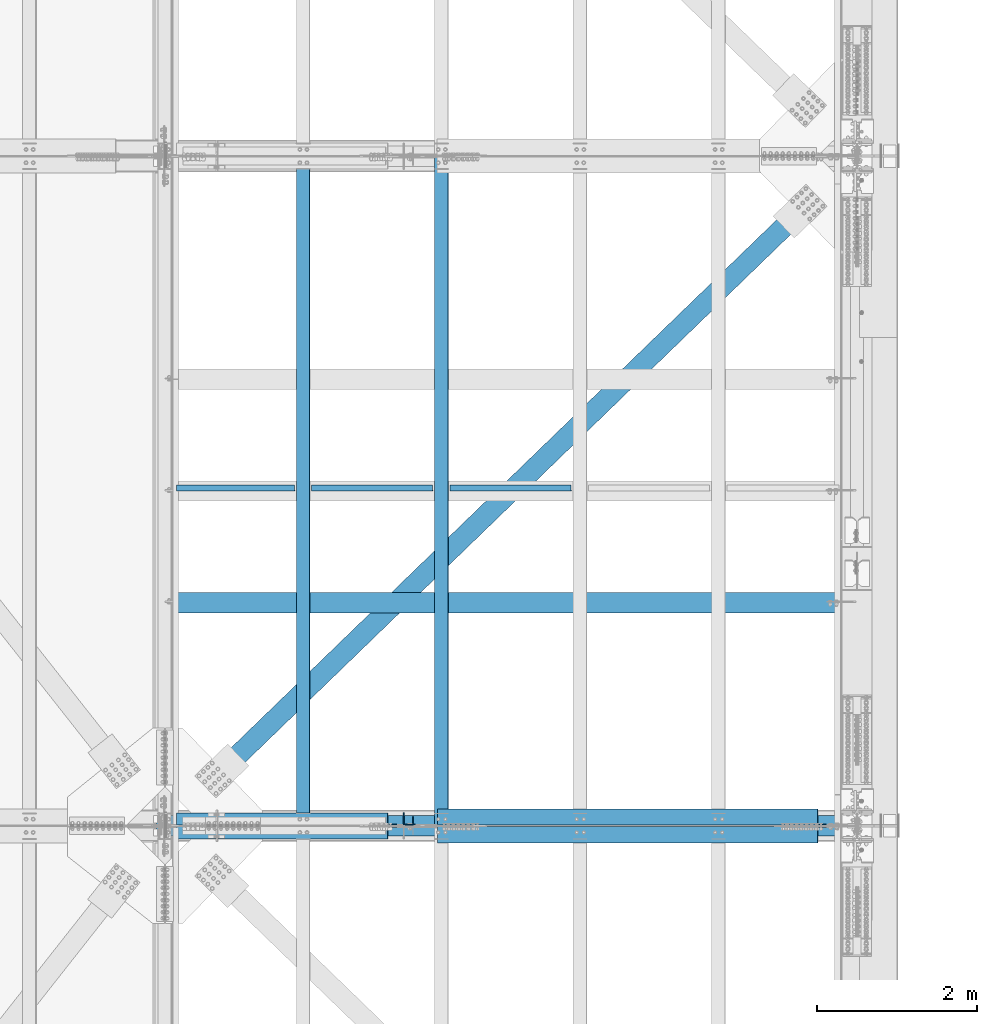
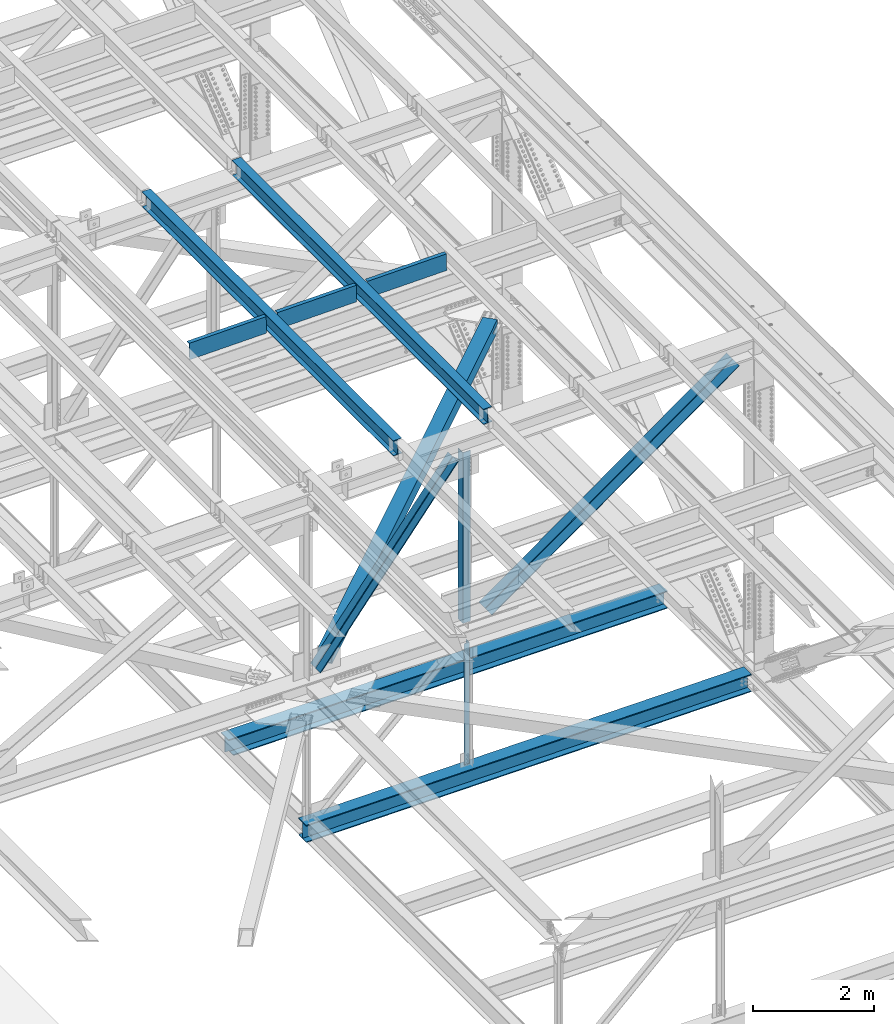
# One storey, part 1972 of 3843: 10 beams, 4 members, 14 elements without a shape of their own.
"""IFC2X3 building model written with IfcOpenShell, lengths in millimetres."""

from ifc_helpers import new_model, si_unit, frame, origin_with_axes, place, context, subcontext, project, spatial, faceted_brep, material, type_object, element, aggregate, save


model = new_model("IFC2X3")

# Units and contexts
model_context = context("Model", 3, precision=1e-05, world=origin_with_axes())
body_context = subcontext(model_context, "Body", "Model", "MODEL_VIEW")
ifc_project = project(units=[si_unit("LENGTHUNIT", "METRE", prefix="MILLI"), si_unit("AREAUNIT", "SQUARE_METRE"), si_unit("VOLUMEUNIT", "CUBIC_METRE"), si_unit("MASSUNIT", "GRAM", prefix="KILO"), si_unit("TIMEUNIT", "SECOND"), si_unit("PLANEANGLEUNIT", "RADIAN"), si_unit("SOLIDANGLEUNIT", "STERADIAN"), si_unit("THERMODYNAMICTEMPERATUREUNIT", "DEGREE_CELSIUS"), si_unit("LUMINOUSINTENSITYUNIT", "LUMEN")], contexts=[model_context])

# Site, building, storey
site_placement = place(None, origin_with_axes())
site = spatial("IfcSite", under=ifc_project, at=site_placement, CompositionType="ELEMENT")
building_placement = place(site_placement, origin_with_axes())
building = spatial("IfcBuilding", under=site, at=building_placement, Name="Undefined", CompositionType="ELEMENT")
storey_placement = place(building_placement, origin_with_axes())
storey = spatial("IfcBuildingStorey", under=building, at=storey_placement, Name="Undefined", CompositionType="ELEMENT", Elevation=0.0)

# Assembly, beam
assembly_1_placement = place(storey_placement, origin_with_axes())
assembly_1 = element("IfcElementAssembly", 1, at=assembly_1_placement, inside=storey, Name="ANGLE", AssemblyPlace="NOTDEFINED", PredefinedType="RIGID_FRAME")
ifc_material_1 = material(Name="STEEL/A572-50")
beam_type_1 = type_object("IfcBeamType", Name="L4X4X3/8", PredefinedType="NOTDEFINED")
beam_1_placement = place(assembly_1_placement, frame((80060.8, 58975.625, 42337.1940566244), z_axis=(-1.0, 0.0, 0.0), x_axis=(0.0, 0.0, -1.0)))
beam_1 = element("IfcBeam", 2, at=beam_1_placement, type_object=beam_type_1, material=ifc_material_1, Name="ANGLE", ObjectType="L4X4X3/8", context=body_context, shape_type="Brep", body=[
    faceted_brep([(208.997248726504, 50.8000000000029, -50.8000000000029), (208.997248726504, 50.8000000000029, 50.8000000000029), (2659.86733991184, 50.8000000000029, 50.8000000000029), (2659.86733991184, 50.8000000000029, -50.8000000000029), (208.997248726504, 41.2750000000015, 50.8000000000029), (2659.86733991184, 41.2750000000015, 50.8000000000029), (208.997248726504, 41.2750000000015, -41.2749999999942), (2659.86733991184, 41.2750000000015, -41.2749999999942), (208.997248726504, -50.8000000000029, -41.2749999999942), (2659.86733991184, -50.8000000000029, -41.2749999999942), (208.997248726504, -50.8000000000029, -50.8000000000029), (2659.86733991184, -50.8000000000029, -50.8000000000029)], [[[0, 1, 2, 3]], [[1, 4, 5, 2]], [[4, 6, 7, 5]], [[6, 8, 9, 7]], [[8, 10, 11, 9]], [[10, 0, 3, 11]], [[5, 7, 9, 11, 3, 2]], [[10, 8, 6, 4, 1, 0]]]),
])
aggregate(assembly_1, [beam_1])

assembly_2_placement = place(storey_placement, origin_with_axes())
assembly_2 = element("IfcElementAssembly", 3, at=assembly_2_placement, inside=storey, Name="BEAM", AssemblyPlace="NOTDEFINED", PredefinedType="RIGID_FRAME")
ifc_material_2 = material(Name="STEEL/A992")
beam_type_2 = type_object("IfcBeamType", Name="W12X26", PredefinedType="NOTDEFINED")
beam_2_placement = place(assembly_2_placement, frame((80463.909262389, 58915.3983935772, 46592.2546931434), z_axis=(-0.0211520982257644, 0.00063245100018685, 0.999776069300711), x_axis=(2.19999991776632e-08, 0.999999799913661, -0.000632591999945398)))
beam_2 = element("IfcBeam", 4, at=beam_2_placement, type_object=beam_type_2, material=ifc_material_2, Name="BEAM", ObjectType="W12X26", context=body_context, shape_type="Brep", body=[
    faceted_brep([(12.7011052740709, 82.550000000163, -155.575000000317), (12.6950811777642, 82.5500000001775, -146.050000000301), (8343.89674809582, 82.5499999787862, -146.049999973642), (8343.90277219211, 82.5499999787717, -155.574999973665), (12.6940208345186, 3.17499999974098, -146.050000000301), (8343.89568775256, 3.17499997834966, -146.049999973642), (12.5092818811318, 3.17500000026484, 146.050000000389), (8343.71094879918, 3.17499997887353, 146.05000002704), (12.5103422243774, 82.5500000007014, 146.050000000389), (8343.71200914242, 82.5499999793101, 146.05000002704), (12.5043181280635, 82.550000000716, 155.575000000419), (8343.70598504612, 82.5499999793246, 155.575000027071), (12.5021126141219, -82.5500000002066, 155.575000000419), (8343.70377953217, -82.5500000215834, 155.575000027071), (12.5081367104212, -82.5500000002357, 146.050000000389), (8343.70980362848, -82.5500000216271, 146.05000002704), (12.5091970536669, -3.17499999978463, 146.050000000389), (8343.71086397171, -3.1750000211614, 146.05000002704), (12.6939360070683, -3.1750000003085, -146.050000000301), (8343.89560292511, -3.17500002169982, -146.049999973642), (12.6928756638226, -82.5500000007596, -146.050000000301), (8343.89454258186, -82.5500000221509, -146.049999973642), (12.698899760122, -82.5500000007742, -155.575000000317), (8343.90056667817, -82.5500000221655, -155.574999973665)], [[[0, 1, 2, 3]], [[1, 4, 5, 2]], [[4, 6, 7, 5]], [[6, 8, 9, 7]], [[8, 10, 11, 9]], [[10, 12, 13, 11]], [[12, 14, 15, 13]], [[14, 16, 17, 15]], [[16, 18, 19, 17]], [[18, 20, 21, 19]], [[20, 22, 23, 21]], [[22, 0, 3, 23]], [[5, 7, 9, 11, 13, 15, 17, 19, 21, 23, 3, 2]], [[22, 20, 18, 16, 14, 12, 10, 8, 6, 4, 1, 0]]]),
])
aggregate(assembly_2, [beam_2])

assembly_3_placement = place(storey_placement, origin_with_axes())
assembly_3 = element("IfcElementAssembly", 5, at=assembly_3_placement, inside=storey, Name="BEAM", AssemblyPlace="NOTDEFINED", PredefinedType="RIGID_FRAME")
beam_3_placement = place(assembly_3_placement, frame((78736.7092624125, 58915.3943655038, 46558.3500046998), z_axis=(-0.0211520978869958, 0.000606560000211177, 0.999776085351088), x_axis=(2.19999995306454e-08, 0.999999815960571, -0.00060669499997619)))
beam_3 = element("IfcBeam", 6, at=beam_3_placement, type_object=beam_type_2, material=ifc_material_2, Name="BEAM", ObjectType="W12X26", context=body_context, shape_type="Brep", body=[
    faceted_brep([(12.7011052740709, 82.550000000163, -155.575000000317), (12.6952824190448, 82.5500000002939, -146.050000000556), (8343.89681571124, 82.5499999796593, -146.050000008661), (8343.90259319375, 82.5499999796593, -155.575000008685), (12.6942655559615, 3.17499999984284, -146.050000000381), (8343.89579884816, 3.17499997922278, -146.050000008487), (12.5170894254115, 3.17500000010477, 146.050000000352), (8343.7186227176, 3.17499997948471, 146.049999992247), (12.5181062884949, 82.5500000005559, 146.050000000178), (8343.7196395807, 82.5499999799358, 146.049999992065), (12.5123288059767, 82.5500000005559, 155.575000000194), (8343.71386209816, 82.5499999799358, 155.574999992095), (12.5102137307549, -82.5500000003813, 155.575000000557), (8343.71174702294, -82.5500000210013, 155.574999992459), (12.5159912132804, -82.5500000003667, 146.050000000541), (8343.71752450548, -82.5500000210013, 146.049999992429), (12.5170080763637, -3.17499999993015, 146.050000000367), (8343.71854136855, -3.17500002056477, 146.049999992261), (12.6941842069136, -3.17500000017753, -146.050000000374), (8343.89571749911, -3.17500002081215, -146.050000008472), (12.6931673438303, -82.5500000006286, -146.050000000192), (8343.89468100455, -82.5499999998865, -146.050000014839), (12.698899760122, -82.5500000007742, -155.575000000317), (8343.90047811854, -82.5500000212778, -155.575000008314)], [[[0, 1, 2, 3]], [[1, 4, 5, 2]], [[4, 6, 7, 5]], [[6, 8, 9, 7]], [[8, 10, 11, 9]], [[10, 12, 13, 11]], [[12, 14, 15, 13]], [[14, 16, 17, 15]], [[16, 18, 19, 17]], [[18, 20, 21, 19]], [[20, 22, 23, 21]], [[22, 0, 3, 23]], [[5, 7, 9, 11, 13, 15, 17, 19, 21, 23, 3, 2]], [[22, 20, 18, 16, 14, 12, 10, 8, 6, 4, 1, 0]]]),
])
aggregate(assembly_3, [beam_3])

assembly_4_placement = place(storey_placement, origin_with_axes())
assembly_4 = element("IfcElementAssembly", 7, at=assembly_4_placement, inside=storey, Name="BENT_PLATE", AssemblyPlace="NOTDEFINED", PredefinedType="RIGID_FRAME")
ifc_material_3 = material(Name="STEEL/A36")
beam_type_3 = type_object("IfcBeamType", PredefinedType="NOTDEFINED")
beam_4_placement = place(assembly_4_placement, frame((77895.7274919524, 63098.3625000036, 46362.5752806988), z_axis=(-0.999843583960508, 0.0, -0.0176863679992966), x_axis=(-0.0176863679992983, 0.0, 0.999843583960508)))
beam_4 = element("IfcBeam", 8, at=beam_4_placement, type_object=beam_type_3, material=ifc_material_3, Name="BENT_PLATE", context=body_context, shape_type="Brep", body=[
    faceted_brep([(2.31375452131033e-09, -4.76249999999709, -736.599999997517), (-2.30647856369615e-09, -4.76249999999709, 736.599999997474), (-2.30647856369615e-09, 4.76249999999709, 736.599999997474), (2.31375452131033e-09, 4.76249999999709, -736.599999997517), (327.024999947338, 4.76250000002619, 736.600000004051), (327.024999981979, 4.76250000002619, -736.600000004313), (336.549999981966, -4.76249999996799, -736.600000004328), (336.549999947325, -4.76249999996799, 736.600000004051), (327.024999959613, 71.4375000200889, 736.600000005245), (327.024999969712, 71.4375000446889, -736.60000000312), (336.549999959585, 71.4375000200962, 736.600000005245), (336.549999969691, 71.4375000446962, -736.600000003134)], [[[0, 1, 2, 3]], [[3, 2, 4, 5]], [[1, 0, 6, 7]], [[5, 4, 8, 9]], [[4, 2, 1, 7, 10, 8]], [[7, 6, 11, 10]], [[6, 0, 3, 5, 9, 11]], [[10, 11, 9, 8]]]),
])
aggregate(assembly_4, [beam_4])

assembly_5_placement = place(storey_placement, origin_with_axes())
assembly_5 = element("IfcElementAssembly", 9, at=assembly_5_placement, inside=storey, Name="BENT_PLATE", AssemblyPlace="NOTDEFINED", PredefinedType="RIGID_FRAME")
beam_5_placement = place(assembly_5_placement, frame((79602.4297787395, 63098.3625000037, 46392.7857615998), z_axis=(-0.999843583960508, 0.0, -0.0176863679992966), x_axis=(-0.0176863679992983, 0.0, 0.999843583960508)))
beam_5 = element("IfcBeam", 10, at=beam_5_placement, type_object=beam_type_3, material=ifc_material_3, Name="BENT_PLATE", context=body_context, shape_type="Brep", body=[
    faceted_brep([(2.38651409745216e-09, -4.76249999999709, -755.649999997448), (-2.37923813983798e-09, -4.76249999999709, 755.649999997433), (-2.37923813983798e-09, 4.76249999999709, 755.649999997433), (2.38651409745216e-09, 4.76249999999709, -755.649999997448), (327.024999945941, 4.76250000002619, 755.650000004171), (327.024999981295, 4.76250000002619, -755.650000004418), (336.549999981282, -4.76249999996799, -755.650000004447), (336.549999945928, -4.76249999996799, 755.650000004156), (327.024999958514, 71.4375000207219, 755.650000005364), (327.024999968708, 71.4375000458094, -755.650000003239), (336.549999958501, 71.4375000207219, 755.650000005349), (336.549999968687, 71.4375000458094, -755.650000003254)], [[[0, 1, 2, 3]], [[3, 2, 4, 5]], [[1, 0, 6, 7]], [[5, 4, 8, 9]], [[4, 2, 1, 7, 10, 8]], [[7, 6, 11, 10]], [[6, 0, 3, 5, 9, 11]], [[10, 11, 9, 8]]]),
])
aggregate(assembly_5, [beam_5])

assembly_6_placement = place(storey_placement, origin_with_axes())
assembly_6 = element("IfcElementAssembly", 11, at=assembly_6_placement, inside=storey, Name="BENT_PLATE", AssemblyPlace="NOTDEFINED", PredefinedType="RIGID_FRAME")
beam_6_placement = place(assembly_6_placement, frame((81329.6291454231, 63098.3625000037, 46423.3405616883), z_axis=(-0.999843583960508, 0.0, -0.0176863679992966), x_axis=(-0.0176863679992983, 0.0, 0.999843583960508)))
beam_6 = element("IfcBeam", 12, at=beam_6_placement, type_object=beam_type_3, material=ifc_material_3, Name="BENT_PLATE", context=body_context, shape_type="Brep", body=[
    faceted_brep([(2.38651409745216e-09, -4.76249999999709, -755.649999997448), (-2.37923813983798e-09, -4.76249999999709, 755.649999997433), (-2.37923813983798e-09, 4.76249999999709, 755.649999997433), (2.38651409745216e-09, 4.76249999999709, -755.649999997448), (327.024999945941, 4.76250000002619, 755.650000004171), (327.024999981295, 4.76250000002619, -755.650000004418), (336.549999981282, -4.76249999996799, -755.650000004447), (336.549999945928, -4.76249999996799, 755.650000004156), (327.024999958514, 71.4375000207219, 755.650000005364), (327.024999968708, 71.4375000458094, -755.650000003239), (336.549999958501, 71.4375000207219, 755.650000005349), (336.549999968687, 71.4375000458094, -755.650000003254)], [[[0, 1, 2, 3]], [[3, 2, 4, 5]], [[1, 0, 6, 7]], [[5, 4, 8, 9]], [[4, 2, 1, 7, 10, 8]], [[7, 6, 11, 10]], [[6, 0, 3, 5, 9, 11]], [[10, 11, 9, 8]]]),
])
aggregate(assembly_6, [beam_6])

# Assembly, member
assembly_7_placement = place(storey_placement, origin_with_axes())
assembly_7 = element("IfcElementAssembly", 13, at=assembly_7_placement, inside=storey, Name="ANGLE", AssemblyPlace="NOTDEFINED", PredefinedType="RIGID_FRAME")
member_type_1 = type_object("IfcMemberType", Name="L8X8X1/2", PredefinedType="NOTDEFINED")
member_1_placement = place(assembly_7_placement, frame((85648.8, 59026.425, 46335.9221366136), z_axis=(0.0, 1.0, 0.0), x_axis=(-0.813230724000052, 0.0, -0.581941397000035)))
member_1 = element("IfcMember", 14, at=member_1_placement, type_object=member_type_1, material=ifc_material_1, Name="ANGLE", ObjectType="L8X8X1/2", context=body_context, shape_type="Brep", body=[
    faceted_brep([(538.735498343696, 101.599999999675, -101.599999999999), (538.735498343696, 101.599999999675, 101.599999999999), (6369.12494995302, 101.599999993818, 101.599999999999), (6369.12494995302, 101.599999993818, -101.599999999999), (538.735498343711, 88.8999999996413, 101.599999999999), (6369.12494995302, 88.8999999937987, 101.599999999999), (538.735498343711, 88.8999999996413, -88.9000000000015), (6369.12494995302, 88.8999999937987, -88.9000000000015), (538.735498343711, -101.600000000752, -88.9000000000015), (6369.12494995302, -101.600000006609, -88.9000000000015), (538.735498343711, -101.600000000752, -101.599999999999), (6369.12494995302, -101.600000006609, -101.599999999999)], [[[0, 1, 2, 3]], [[1, 4, 5, 2]], [[4, 6, 7, 5]], [[6, 8, 9, 7]], [[8, 10, 11, 9]], [[10, 0, 3, 11]], [[5, 7, 9, 11, 3, 2]], [[10, 8, 6, 4, 1, 0]]]),
])
aggregate(assembly_7, [member_1])

assembly_8_placement = place(storey_placement, origin_with_axes())
assembly_8 = element("IfcElementAssembly", 15, at=assembly_8_placement, inside=storey, Name="ANGLE", AssemblyPlace="NOTDEFINED", PredefinedType="RIGID_FRAME")
member_2_placement = place(assembly_8_placement, frame((80060.7999993134, 58804.175, 42337.1940577753), z_axis=(0.0, -1.0, 0.0), x_axis=(0.813230724000049, 0.0, 0.581941397000038)))
member_2 = element("IfcMember", 16, at=member_2_placement, type_object=member_type_1, material=ifc_material_1, Name="ANGLE", ObjectType="L8X8X1/2", context=body_context, shape_type="Brep", body=[
    faceted_brep([(502.233740769108, 101.600000000715, -101.599999999999), (502.233740769108, 101.600000000715, 101.599999999999), (6332.62319237844, 101.600000006572, 101.599999999999), (6332.62319237844, 101.600000006572, -101.599999999999), (502.233740769123, 88.9000000006963, 101.599999999999), (6332.62319237844, 88.9000000065462, 101.599999999999), (502.233740769123, 88.9000000006963, -88.9000000000015), (6332.62319237844, 88.9000000065462, -88.9000000000015), (502.233740769108, -101.599999999711, -88.9000000000015), (6332.62319237845, -101.599999993861, -88.9000000000015), (502.233740769108, -101.599999999711, -101.599999999999), (6332.62319237845, -101.599999993861, -101.599999999999)], [[[0, 1, 2, 3]], [[1, 4, 5, 2]], [[4, 6, 7, 5]], [[6, 8, 9, 7]], [[8, 10, 11, 9]], [[10, 0, 3, 11]], [[5, 7, 9, 11, 3, 2]], [[10, 8, 6, 4, 1, 0]]]),
])
aggregate(assembly_8, [member_2])

assembly_9_placement = place(storey_placement, origin_with_axes())
assembly_9 = element("IfcElementAssembly", 17, at=assembly_9_placement, inside=storey, Name="ANGLE", AssemblyPlace="NOTDEFINED", PredefinedType="RIGID_FRAME")
member_type_2 = type_object("IfcMemberType", Name="L6X6X1/2", PredefinedType="NOTDEFINED")
member_3_placement = place(assembly_9_placement, frame((80060.8, 59001.025, 46232.1299047932), z_axis=(0.0, 1.0, 0.0), x_axis=(-0.61680932466707, 0.0, -0.787112607575151)))
member_3 = element("IfcMember", 18, at=member_3_placement, type_object=member_type_2, material=ifc_material_1, Name="ANGLE", ObjectType="L6X6X1/2", context=body_context, shape_type="Brep", body=[
    faceted_brep([(348.129940100785, 76.1999999996769, -76.1999999999971), (348.129940100785, 76.1999999996769, 76.1999999999971), (4616.09516767267, 76.1999999944819, 76.1999999999971), (4616.09516767267, 76.1999999944819, -76.1999999999971), (348.1299401008, 63.4999999996653, 76.1999999999971), (4616.09516767267, 63.4999999944703, 76.1999999999971), (348.1299401008, 63.4999999996653, -63.5), (4616.09516767267, 63.4999999944703, -63.5), (348.129940100785, -76.2000000005282, -63.5), (4616.09516767265, -76.2000000057305, -63.5), (348.129940100785, -76.2000000005282, -76.1999999999971), (4616.09516767265, -76.2000000057305, -76.1999999999971)], [[[0, 1, 2, 3]], [[1, 4, 5, 2]], [[4, 6, 7, 5]], [[6, 8, 9, 7]], [[8, 10, 11, 9]], [[10, 0, 3, 11]], [[5, 7, 9, 11, 3, 2]], [[10, 8, 6, 4, 1, 0]]]),
])
aggregate(assembly_9, [member_3])

assembly_10_placement = place(storey_placement, origin_with_axes())
assembly_10 = element("IfcElementAssembly", 19, at=assembly_10_placement, inside=storey, Name="ANGLE", AssemblyPlace="NOTDEFINED", PredefinedType="RIGID_FRAME")
member_4_placement = place(assembly_10_placement, frame((77012.7999979159, 58829.575, 42342.5660912394), z_axis=(0.0, -1.0, 0.0), x_axis=(0.616809324667073, 0.0, 0.787112607575148)))
member_4 = element("IfcMember", 20, at=member_4_placement, type_object=member_type_2, material=ifc_material_1, Name="ANGLE", ObjectType="L6X6X1/2", context=body_context, shape_type="Brep", body=[
    faceted_brep([(325.464370828078, 76.2000000005064, -76.1999999999971), (325.464370828078, 76.2000000005064, 76.1999999999971), (4593.42959839995, 76.200000005716, 76.1999999999971), (4593.42959839995, 76.200000005716, -76.1999999999971), (325.464370828078, 63.5000000004802, 76.1999999999971), (4593.42959839995, 63.5000000057044, 76.1999999999971), (325.464370828078, 63.5000000004802, -63.5), (4593.42959839995, 63.5000000057044, -63.5), (325.464370828078, -76.1999999997061, -63.5), (4593.42959839995, -76.1999999944819, -63.5), (325.464370828078, -76.1999999997061, -76.1999999999971), (4593.42959839995, -76.1999999944819, -76.1999999999971)], [[[0, 1, 2, 3]], [[1, 4, 5, 2]], [[4, 6, 7, 5]], [[6, 8, 9, 7]], [[8, 10, 11, 9]], [[10, 0, 3, 11]], [[5, 7, 9, 11, 3, 2]], [[10, 8, 6, 4, 1, 0]]]),
])
aggregate(assembly_10, [member_4])

# Assembly, beam
assembly_11_placement = place(storey_placement, origin_with_axes())
assembly_11 = element("IfcElementAssembly", 21, at=assembly_11_placement, inside=storey, Name="ANGLE", AssemblyPlace="NOTDEFINED", PredefinedType="RIGID_FRAME")
beam_type_4 = type_object("IfcBeamType", Name="L6X6X1/2", PredefinedType="NOTDEFINED")
beam_7_placement = place(assembly_11_placement, frame((80060.8000002469, 59001.025, 46232.1579029144), z_axis=(0.0, 1.0, 0.0), x_axis=(0.0, 0.0, -1.0)))
beam_7 = element("IfcBeam", 22, at=beam_7_placement, type_object=beam_type_4, material=ifc_material_1, Name="ANGLE", ObjectType="L6X6X1/2", context=body_context, shape_type="Brep", body=[
    faceted_brep([(224.448834853647, 76.1999999999971, -76.1999999999971), (224.448834853647, 76.1999999999971, 76.1999999999971), (3683.77568244976, 76.1999999999971, 76.1999999999971), (3683.77568244976, 76.1999999999971, -76.1999999999971), (224.448834853647, 63.5, 76.1999999999971), (3683.77568244976, 63.5, 76.1999999999971), (224.448834853647, 63.5, -63.5), (3683.77568244976, 63.5, -63.5), (224.448834853647, -76.1999999999971, -63.5), (3683.77568244976, -76.1999999999971, -63.5), (224.448834853647, -76.1999999999971, -76.1999999999971), (3683.77568244976, -76.1999999999971, -76.1999999999971)], [[[0, 1, 2, 3]], [[1, 4, 5, 2]], [[4, 6, 7, 5]], [[6, 8, 9, 7]], [[8, 10, 11, 9]], [[10, 0, 3, 11]], [[5, 7, 9, 11, 3, 2]], [[10, 8, 6, 4, 1, 0]]]),
])
aggregate(assembly_11, [beam_7])

assembly_12_placement = place(storey_placement, origin_with_axes())
assembly_12 = element("IfcElementAssembly", 23, at=assembly_12_placement, inside=storey, AssemblyPlace="NOTDEFINED", PredefinedType="RIGID_FRAME")
ifc_material_4 = material()
beam_type_5 = type_object("IfcBeamType", Name="HSS10X10X3/4", PredefinedType="NOTDEFINED")
beam_8_placement = place(assembly_12_placement, frame((77012.8, 58915.3, 42246.55), z_axis=(0.695386218410511, -0.718636213424239, 0.0), x_axis=(0.718636212924514, 0.695386218926945, 0.0)))
beam_8 = element("IfcBeam", 24, at=beam_8_placement, type_object=beam_type_5, material=ifc_material_4, ObjectType="HSS10X10X3/4", context=body_context, shape_type="Brep", body=[
    faceted_brep([(10996.200705996, 26.9869994955006, 127.0000000414), (10743.7881939004, 26.9869994955006, 127.00000004044), (10743.7881939003, 26.9869994955006, 107.950000040495), (10996.200705996, 26.9869994955006, 107.950000041463), (10738.3206042145, 25.8994282872154, 127.000000040418), (10738.3206042144, 25.8994282872154, 107.950000040481), (10733.6854054944, 22.8022875199749, 127.000000040396), (10733.6854054943, 22.8022875199749, 107.950000040451), (10730.5882647272, 18.167088799928, 127.000000040389), (10730.588264727, 18.167088799928, 107.950000040451), (10729.5006935189, 12.6994991140309, 127.000000040389), (10729.5006935188, 12.6994991140309, 107.950000040444), (10730.5882647272, 7.23191019107617, 127.000000040389), (10730.588264727, 7.23191019107617, 107.950000040451), (10733.6854054944, 2.59671147102927, 127.000000040396), (10733.6854054943, 2.59671147102927, 107.950000040451), (10738.3206042145, -0.500429296211223, 127.000000040418), (10738.3206042144, -0.500429296211223, 107.950000040481), (10743.7881939004, -1.58800050449645, 127.00000004044), (10743.7881939003, -1.58800050449645, 107.950000040495), (10996.200705996, -1.58800050449645, 127.0000000414), (10996.200705996, -1.58800050449645, 107.950000041463), (10996.2007059956, 26.9869994955006, -107.949999957877), (10743.7881938989, 26.9869994955006, -107.94999995883), (10743.7881938988, 26.9869994955006, -126.999999958774), (10996.2007059956, 26.9869994955006, -126.999999957814), (10738.320604213, 25.8994282872154, -107.949999958859), (10738.3206042129, 25.8994282872154, -126.999999958789), (10733.6854054929, 22.8022875199749, -107.949999958881), (10733.6854054928, 22.8022875199749, -126.999999958811), (10730.5882647257, 18.167088799928, -107.949999958888), (10730.5882647255, 18.167088799928, -126.999999958818), (10729.5006935174, 12.6994991140309, -107.949999958888), (10729.5006935173, 12.6994991140309, -126.999999958833), (10730.5882647257, 7.23191019107617, -107.949999958888), (10730.5882647255, 7.23191019107617, -126.999999958818), (10733.6854054929, 2.59671147102927, -107.949999958881), (10733.6854054928, 2.59671147102927, -126.999999958811), (10738.320604213, -0.500429296211223, -107.949999958859), (10738.3206042129, -0.500429296211223, -126.999999958789), (10743.7881938989, -1.58800050449645, -107.94999995883), (10743.7881938988, -1.58800050449645, -126.999999958774), (10996.2007059956, -1.58800050449645, -107.949999957877), (10996.2007059956, -1.58800050449645, -126.999999957814), (1018.02056851298, 107.949999999997, 107.950000003533), (1018.02056851263, 107.949999999997, -107.949999995799), (10996.2007059956, 107.949999999997, -107.949999957877), (10996.200705996, 107.949999999997, 107.950000041463), (10996.200705996, -107.949999999997, 107.950000041463), (1018.02056851298, -107.949999999997, 107.950000003533), (1018.02056851298, -1.58800048788544, 107.950000003533), (1270.43308035456, -1.58800048788544, 107.95000000449), (1275.90067004044, -0.500429279600212, 107.950000004515), (1280.53586876049, 2.59671148764028, 107.950000004523), (1283.63300952772, 7.23191020768718, 107.950000004545), (1284.72058073602, 12.6994991306419, 107.950000004548), (1283.63300952772, 18.167088816539, 107.950000004545), (1280.53586876049, 22.8022875365859, 107.950000004523), (1275.90067004044, 25.8994283038264, 107.950000004515), (1270.43308035456, 26.9869995121117, 107.95000000449), (1018.02056851298, 26.9869995121117, 107.950000003533), (1018.02056851263, -107.949999999997, -107.949999995799), (10996.2007059956, -107.949999999997, -107.949999957877), (1018.02056851263, 26.9869995121117, -107.949999995799), (1270.43308035316, 26.9869995121117, -107.949999994842), (1275.90067003905, 25.8994283038264, -107.949999994817), (1280.53586875909, 22.8022875365859, -107.949999994802), (1283.63300952633, 18.167088816539, -107.949999994788), (1284.72058073462, 12.6994991306419, -107.949999994784), (1283.63300952633, 7.23191020768718, -107.949999994788), (1280.53586875909, 2.59671148764028, -107.949999994802), (1275.90067003905, -0.500429279600212, -107.949999994817), (1270.43308035316, -1.58800048788544, -107.949999994842), (1018.02056851263, -1.58800048788544, -107.949999995799), (1018.02056851258, 26.9869995121117, -126.999999995736), (1270.43308035303, 26.9869995121117, -126.999999994787), (1275.90067003893, 25.8994283038264, -126.999999994761), (1280.53586875896, 22.8022875365859, -126.999999994747), (1283.63300952621, 18.167088816539, -126.999999994725), (1284.72058073449, 12.6994991306419, -126.999999994729), (1283.63300952621, 7.23191020768718, -126.999999994725), (1280.53586875896, 2.59671148764028, -126.999999994747), (1275.90067003893, -0.500429279600212, -126.999999994761), (1270.43308035303, -1.58800048788544, -126.999999994787), (1018.02056851258, -1.58800048788544, -126.999999995736), (1018.02056851258, -127.0, -126.999999995736), (1018.02056851302, -127.0, 127.000000003467), (1018.02056851302, -1.58800048788544, 127.000000003467), (1270.43308035469, -1.58800048788544, 127.000000004435), (1275.90067004057, -0.500429279600212, 127.00000000446), (1280.53586876062, 2.59671148764028, 127.000000004475), (1283.63300952785, 7.23191020768718, 127.000000004489), (1284.72058073613, 12.6994991306419, 127.000000004493), (1283.63300952785, 18.167088816539, 127.000000004489), (1280.53586876062, 22.8022875365859, 127.000000004475), (1275.90067004057, 25.8994283038264, 127.00000000446), (1270.43308035469, 26.9869995121117, 127.000000004435), (1018.02056851302, 26.9869995121117, 127.000000003467), (1018.02056851302, 127.0, 127.000000003467), (1018.02056851258, 127.0, -126.999999995736), (10996.200705996, 127.0, 127.0000000414), (10996.2007059956, 127.0, -126.999999957814), (10996.2007059956, -127.0, -126.999999957814), (10996.200705996, -127.0, 127.0000000414)], [[[0, 1, 2, 3]], [[4, 5, 2, 1]], [[6, 7, 5, 4]], [[8, 9, 7, 6]], [[10, 11, 9, 8]], [[12, 13, 11, 10]], [[14, 15, 13, 12]], [[16, 17, 15, 14]], [[18, 19, 17, 16]], [[20, 21, 19, 18]], [[22, 23, 24, 25]], [[26, 27, 24, 23]], [[28, 29, 27, 26]], [[30, 31, 29, 28]], [[32, 33, 31, 30]], [[34, 35, 33, 32]], [[36, 37, 35, 34]], [[38, 39, 37, 36]], [[40, 41, 39, 38]], [[42, 43, 41, 40]], [[44, 45, 46, 47]], [[48, 49, 50, 51, 52, 53, 54, 55, 56, 57, 58, 59, 60, 44, 47, 3, 2, 5, 7, 9, 11, 13, 15, 17, 19, 21]], [[61, 49, 48, 62]], [[38, 36, 34, 32, 30, 28, 26, 23, 22, 46, 45, 63, 64, 65, 66, 67, 68, 69, 70, 71, 72, 73, 61, 62, 42, 40]], [[63, 74, 75, 64]], [[64, 75, 76, 65]], [[65, 76, 77, 66]], [[66, 77, 78, 67]], [[67, 78, 79, 68]], [[68, 79, 80, 69]], [[69, 80, 81, 70]], [[70, 81, 82, 71]], [[71, 82, 83, 72]], [[72, 83, 84, 73]], [[49, 61, 73, 84, 85, 86, 87, 50]], [[88, 51, 50, 87]], [[89, 52, 51, 88]], [[90, 53, 52, 89]], [[91, 54, 53, 90]], [[92, 55, 54, 91]], [[93, 56, 55, 92]], [[94, 57, 56, 93]], [[95, 58, 57, 94]], [[96, 59, 58, 95]], [[97, 60, 59, 96]], [[98, 99, 74, 63, 45, 44, 60, 97]], [[99, 98, 100, 101]], [[47, 46, 22, 25, 101, 100, 0, 3]], [[102, 85, 84, 83, 82, 81, 80, 79, 78, 77, 76, 75, 74, 99, 101, 25, 24, 27, 29, 31, 33, 35, 37, 39, 41, 43]], [[86, 85, 102, 103]], [[16, 14, 12, 10, 8, 6, 4, 1, 0, 100, 98, 97, 96, 95, 94, 93, 92, 91, 90, 89, 88, 87, 86, 103, 20, 18]], [[103, 102, 43, 42, 62, 48, 21, 20]]]),
])
aggregate(assembly_12, [beam_8])

assembly_13_placement = place(storey_placement, origin_with_axes())
assembly_13 = element("IfcElementAssembly", 25, at=assembly_13_placement, inside=storey, Name="BEAM", AssemblyPlace="NOTDEFINED", PredefinedType="RIGID_FRAME")
beam_type_6 = type_object("IfcBeamType", Name="W14X68", PredefinedType="NOTDEFINED")
beam_9_placement = place(assembly_13_placement, frame((77011.2455432629, 61700.17188, 39446.1932047752), z_axis=(-0.00874272599685357, 0.0, 0.999961781640751), x_axis=(0.99996178164075, 0.0, 0.00874272599685906)))
beam_9 = element("IfcBeam", 26, at=beam_9_placement, type_object=beam_type_6, material=ifc_material_2, Name="BEAM", ObjectType="W14X68", context=body_context, shape_type="Brep", body=[
    faceted_brep([(18.5345399647922, -5.55625000000146, -146.050000000054), (18.5345399647922, 5.55625000000146, -146.050000000054), (94.4569118349318, 5.55625000000146, -146.049999997376), (94.4569118349318, -5.55625000000146, -146.049999997376), (99.3169913531019, 5.55625000000146, -147.016729919989), (99.3169913531019, -5.55625000000146, -147.016729919989), (103.437167821379, 5.55625000000146, -149.769743820485), (103.437167821379, -5.55625000000146, -149.769743820485), (106.190181721948, 5.55625000000146, -153.889920288661), (106.190181721948, -5.55625000000146, -153.889920288661), (107.15691164459, 5.55625000000146, -158.749999999636), (107.15691164459, -5.55625000000146, -158.749999999636), (107.156911644604, -127.0, -158.749999806714), (107.15691164459, 127.0, -158.749999999636), (107.15691164443, 127.0, -177.799999999566), (107.15691164443, -127.0, -177.799999999566), (21.1994246961403, 5.55625000000146, 158.750000000429), (21.1994246961403, 127.0, 158.750000000429), (8423.36429156657, 127.0, 158.750000031323), (8423.36429156657, 5.55625000000146, 158.750000031323), (21.3659799918532, 127.0, 177.800000000469), (8423.53084686227, 127.0, 177.80000003137), (21.3659799918532, -127.0, 177.800000000469), (8423.53084686227, -127.0, 177.80000003137), (21.1994246961403, -127.0, 158.750000000429), (8423.36429156657, -127.0, 158.750000031323), (21.1994246961403, -5.55625000000146, 158.750000000429), (8423.36429156657, -5.55625000000146, 158.750000031323), (8420.58836997142, 5.55625000000146, -158.749999969383), (8420.58836997142, -5.55625000000146, -158.749999969383), (8420.58836997142, -127.0, -158.749999969383), (8420.4218146757, -127.0, -177.799999969422), (8420.4218146757, 127.0, -177.799999969422), (8420.58836997142, 127.0, -158.749999969383), (18.908174102995, 5.55625000000146, -103.315061415844), (20.9242467178701, 5.55625000000146, 127.276125431534)], [[[0, 1, 2, 3]], [[3, 2, 4, 5]], [[5, 4, 6, 7]], [[7, 6, 8, 9]], [[9, 8, 10, 11]], [[12, 11, 10, 13, 14, 15]], [[16, 17, 18, 19]], [[17, 20, 21, 18]], [[20, 22, 23, 21]], [[22, 24, 25, 23]], [[24, 26, 27, 25]], [[28, 19, 18, 21, 23, 25, 27, 29, 30, 31, 32, 33]], [[31, 30, 12, 15]], [[32, 31, 15, 14]], [[33, 32, 14, 13]], [[28, 33, 13, 10]], [[6, 4, 2, 1, 34, 35, 16, 19, 28, 10, 8]], [[26, 24, 22, 20, 17, 16, 35, 34, 1, 0]], [[29, 27, 26, 0, 3, 5, 7, 9, 11]], [[30, 29, 11, 12]]]),
])
aggregate(assembly_13, [beam_9])

assembly_14_placement = place(storey_placement, origin_with_axes())
assembly_14 = element("IfcElementAssembly", 27, at=assembly_14_placement, inside=storey, Name="BEAM", AssemblyPlace="NOTDEFINED", PredefinedType="RIGID_FRAME")
beam_10_placement = place(assembly_14_placement, frame((76909.6493797588, 58915.3, 39446.1932382766), z_axis=(-0.00872114900049929, 0.0, 0.999961970056917), x_axis=(0.999961970056917, 0.0, 0.00872114900049614)))
beam_10 = element("IfcBeam", 28, at=beam_10_placement, type_object=beam_type_6, material=ifc_material_2, Name="BEAM", ObjectType="W14X68", context=body_context, shape_type="Brep", body=[
    faceted_brep([(1.06228981167078e-09, 127.0, -177.800000000105), (9.45874489843845e-10, 127.0, -158.750000000087), (8522.19023619508, 127.0, -158.749999980777), (8522.02409198816, 127.0, -177.799999980722), (9.45874489843845e-10, 5.55624999999418, -158.750000000087), (8522.19023619508, 5.55625000000146, -158.749999980777), (-9.74978320300579e-10, 5.55624999999418, 158.75000000008), (8524.95930631031, 5.55625000000146, 158.750000018263), (-9.74978320300579e-10, 127.0, 158.75000000008), (8524.95930631031, 127.0, 158.750000018263), (-1.07684172689915e-09, 127.0, 177.80000000009), (8525.12545051723, 127.0, 177.800000018207), (-1.07684172689915e-09, -127.0, 177.80000000009), (8525.12545051723, -127.0, 177.800000018207), (-9.74978320300579e-10, -127.0, 158.75000000008), (8524.95930631031, -127.0, 158.750000018263), (-9.74978320300579e-10, -5.55624999999418, 158.75000000008), (8524.95930631031, -5.55625000000146, 158.750000018263), (9.45874489843845e-10, -5.55624999999418, -158.750000000087), (8522.19023619508, -5.55625000000146, -158.749999980777), (9.45874489843845e-10, -127.0, -158.750000000087), (8522.19023619508, -127.0, -158.749999980777), (1.06228981167078e-09, -127.0, -177.800000000105), (8522.02409198816, -127.0, -177.799999980722)], [[[0, 1, 2, 3]], [[1, 4, 5, 2]], [[4, 6, 7, 5]], [[6, 8, 9, 7]], [[8, 10, 11, 9]], [[10, 12, 13, 11]], [[12, 14, 15, 13]], [[14, 16, 17, 15]], [[16, 18, 19, 17]], [[18, 20, 21, 19]], [[20, 22, 23, 21]], [[22, 0, 3, 23]], [[5, 7, 9, 11, 13, 15, 17, 19, 21, 23, 3, 2]], [[22, 20, 18, 16, 14, 12, 10, 8, 6, 4, 1, 0]]]),
])
aggregate(assembly_14, [beam_10])

save(model, "model.ifc")
